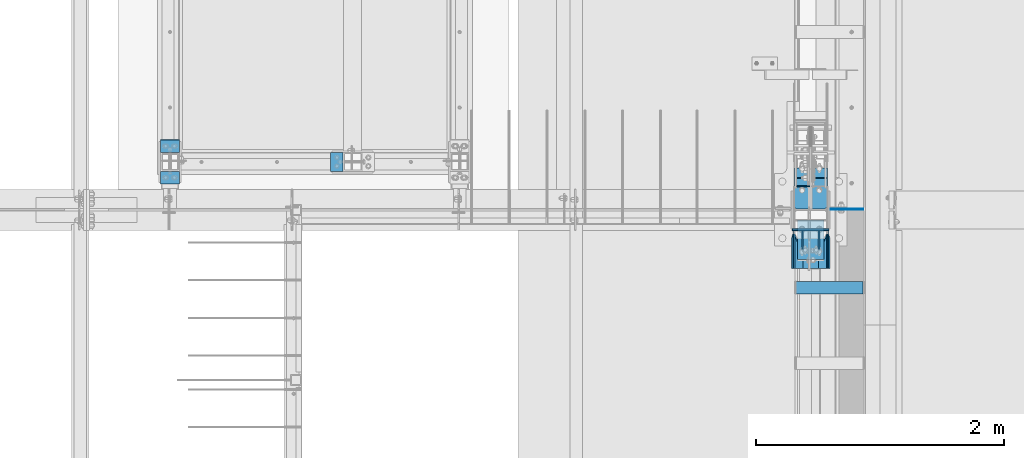
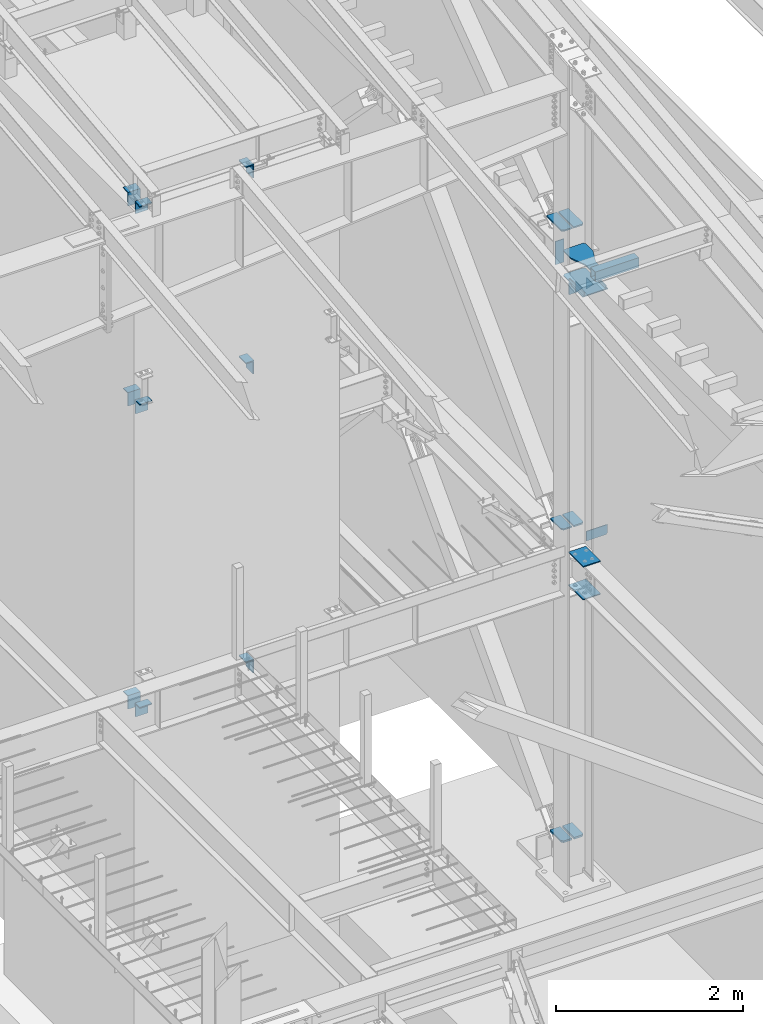
# One storey, part 823 of 1179: 27 beams, 14 elements without a shape of their own.
"""IFC2X3 building model written with IfcOpenShell, lengths in millimetres."""

from ifc_helpers import new_model, si_unit, frame, origin_with_axes, place, context, subcontext, project, spatial, faceted_brep, material, type_object, element, aggregate, save


model = new_model("IFC2X3")

# Units and contexts
model_context = context("Model", 3, precision=1e-05, world=origin_with_axes())
body_context = subcontext(model_context, "Body", "Model", "MODEL_VIEW")
ifc_project = project(units=[si_unit("LENGTHUNIT", "METRE", prefix="MILLI"), si_unit("AREAUNIT", "SQUARE_METRE"), si_unit("VOLUMEUNIT", "CUBIC_METRE"), si_unit("MASSUNIT", "GRAM", prefix="KILO"), si_unit("TIMEUNIT", "SECOND"), si_unit("PLANEANGLEUNIT", "RADIAN"), si_unit("SOLIDANGLEUNIT", "STERADIAN"), si_unit("THERMODYNAMICTEMPERATUREUNIT", "DEGREE_CELSIUS"), si_unit("LUMINOUSINTENSITYUNIT", "LUMEN")], contexts=[model_context])

# Site, building, storey
site_placement = place(None, origin_with_axes())
site = spatial("IfcSite", under=ifc_project, at=site_placement, CompositionType="ELEMENT")
building_placement = place(site_placement, origin_with_axes())
building = spatial("IfcBuilding", under=site, at=building_placement, Name="Undefined", CompositionType="ELEMENT")
storey_placement = place(building_placement, origin_with_axes())
storey = spatial("IfcBuildingStorey", under=building, at=storey_placement, Name="Undefined", CompositionType="ELEMENT", Elevation=0.0)

# Assembly, beams
assembly_1_placement = place(storey_placement, origin_with_axes())
assembly_1 = element("IfcElementAssembly", 1, at=assembly_1_placement, inside=storey, Name="COLUMN", AssemblyPlace="NOTDEFINED", PredefinedType="RIGID_FRAME")
ifc_material_1 = material(Name="STEEL/A36")
beam_type_1 = type_object("IfcBeamType", PredefinedType="NOTDEFINED")
beam_1_placement = place(assembly_1_placement, frame((19138.9, 12045.9499984741, 7658.1), z_axis=(1.0, 0.0, 0.0), x_axis=(0.0, -1.0, 0.0)))
beam_1 = element("IfcBeam", 2, at=beam_1_placement, type_object=beam_type_1, material=ifc_material_1, Name="BENT_PLATE", context=body_context, shape_type="Brep", body=[
    faceted_brep([(7.27595761418343e-12, -6.35000000000036, -76.1999999999971), (0.0, -6.35000000000036, 76.2000000000044), (0.0, 6.35000000000036, 76.2000000000044), (-7.27595761418343e-12, 6.35000000000036, -76.1999999999971), (88.8999984741222, 6.34999999999991, 76.2000000000007), (88.8999984741222, 6.34999999999991, -76.2000000000007), (101.599998474123, -6.34999999999991, -76.2000000000007), (101.599998474123, -6.34999999999991, 76.2000000000007), (88.8999984741222, 171.450003051757, 76.2000000000007), (88.8999984741222, 171.450003051757, -76.2000000000007), (101.599998474123, 171.450003051757, 76.2000000000007), (101.599998474123, 171.450003051757, -76.2000000000007)], [[[0, 1, 2, 3]], [[3, 2, 4, 5]], [[1, 0, 6, 7]], [[5, 4, 8, 9]], [[4, 2, 1, 7, 10, 8]], [[7, 6, 11, 10]], [[6, 0, 3, 5, 9, 11]], [[10, 11, 9, 8]]]),
])
beam_2_placement = place(assembly_1_placement, frame((19138.9, 11690.3500015259, 7658.1), z_axis=(1.0, 0.0, 0.0), x_axis=(0.0, 1.0, 0.0)))
beam_2 = element("IfcBeam", 3, at=beam_2_placement, type_object=beam_type_1, material=ifc_material_1, Name="BENT_PLATE", context=body_context, shape_type="Brep", body=[
    faceted_brep([(7.27595761418343e-12, -6.35000000000036, -76.1999999999971), (0.0, -6.35000000000036, 76.2000000000044), (0.0, 6.35000000000036, 76.2000000000044), (-7.27595761418343e-12, 6.35000000000036, -76.1999999999971), (101.599998474123, 6.34999999999991, 76.2000000000007), (101.599998474123, 6.34999999999991, -76.2000000000007), (88.8999984741222, -6.34999999999991, -76.2000000000007), (88.8999984741222, -6.34999999999991, 76.2000000000007), (101.599998474123, -171.450003051757, 76.2000000000007), (101.599998474123, -171.450003051757, -76.2000000000007), (88.8999984741222, -171.450003051757, 76.2000000000007), (88.8999984741222, -171.450003051757, -76.2000000000007)], [[[0, 1, 2, 3]], [[3, 2, 4, 5]], [[1, 0, 6, 7]], [[5, 4, 8, 9]], [[4, 2, 1, 7, 10, 8]], [[7, 6, 11, 10]], [[6, 0, 3, 5, 9, 11]], [[10, 11, 9, 8]]]),
])
aggregate(assembly_1, [beam_1, beam_2])

assembly_2_placement = place(storey_placement, origin_with_axes())
assembly_2 = element("IfcElementAssembly", 4, at=assembly_2_placement, inside=storey, Name="COLUMN", AssemblyPlace="NOTDEFINED", PredefinedType="RIGID_FRAME")
beam_3_placement = place(assembly_2_placement, frame((19138.899794654, 12045.9499984741, 3692.52499649481), z_axis=(1.0, 0.0, 0.0), x_axis=(0.0, -1.0, 0.0)))
beam_3 = element("IfcBeam", 5, at=beam_3_placement, type_object=beam_type_1, material=ifc_material_1, Name="BENT_PLATE", context=body_context, shape_type="Brep", body=[
    faceted_brep([(7.27595761418343e-12, -6.35000000000036, -76.1999999999971), (0.0, -6.35000000000036, 76.2000000000044), (0.0, 6.35000000000036, 76.2000000000044), (-7.27595761418343e-12, 6.35000000000036, -76.1999999999971), (88.8999984741222, 6.34999999999991, 76.2000000000007), (88.8999984741222, 6.34999999999991, -76.2000000000007), (101.599998474123, -6.34999999999991, -76.2000000000007), (101.599998474123, -6.34999999999991, 76.2000000000007), (88.8999984741222, 171.450003051757, 76.2000000000007), (88.8999984741222, 171.450003051757, -76.2000000000007), (101.599998474123, 171.450003051757, 76.2000000000007), (101.599998474123, 171.450003051757, -76.2000000000007)], [[[0, 1, 2, 3]], [[3, 2, 4, 5]], [[1, 0, 6, 7]], [[5, 4, 8, 9]], [[4, 2, 1, 7, 10, 8]], [[7, 6, 11, 10]], [[6, 0, 3, 5, 9, 11]], [[10, 11, 9, 8]]]),
])
beam_4_placement = place(assembly_2_placement, frame((19138.899794654, 11690.3500015259, 3692.52499649481), z_axis=(1.0, 0.0, 0.0), x_axis=(0.0, 1.0, 0.0)))
beam_4 = element("IfcBeam", 6, at=beam_4_placement, type_object=beam_type_1, material=ifc_material_1, Name="BENT_PLATE", context=body_context, shape_type="Brep", body=[
    faceted_brep([(7.27595761418343e-12, -6.35000000000036, -76.1999999999971), (0.0, -6.35000000000036, 76.2000000000044), (0.0, 6.35000000000036, 76.2000000000044), (-7.27595761418343e-12, 6.35000000000036, -76.1999999999971), (101.599998474123, 6.34999999999991, 76.2000000000007), (101.599998474123, 6.34999999999991, -76.2000000000007), (88.8999984741222, -6.34999999999991, -76.2000000000007), (88.8999984741222, -6.34999999999991, 76.2000000000007), (101.599998474123, -171.450003051757, 76.2000000000007), (101.599998474123, -171.450003051757, -76.2000000000007), (88.8999984741222, -171.450003051757, 76.2000000000007), (88.8999984741222, -171.450003051757, -76.2000000000007)], [[[0, 1, 2, 3]], [[3, 2, 4, 5]], [[1, 0, 6, 7]], [[5, 4, 8, 9]], [[4, 2, 1, 7, 10, 8]], [[7, 6, 11, 10]], [[6, 0, 3, 5, 9, 11]], [[10, 11, 9, 8]]]),
])
aggregate(assembly_2, [beam_3, beam_4])

# Assembly, beam
assembly_3_placement = place(storey_placement, origin_with_axes())
assembly_3 = element("IfcElementAssembly", 7, at=assembly_3_placement, inside=storey, Name="COLUMN", AssemblyPlace="NOTDEFINED", PredefinedType="RIGID_FRAME")
beam_5_placement = place(assembly_3_placement, frame((20434.3000015259, 11868.15, 7658.1), z_axis=(0.0, 1.0, 0.0), x_axis=(1.0, 0.0, 0.0)))
beam_5 = element("IfcBeam", 8, at=beam_5_placement, type_object=beam_type_1, material=ifc_material_1, Name="BENT_PLATE", context=body_context, shape_type="Brep", body=[
    faceted_brep([(7.27595761418343e-12, -6.35000000000036, -76.1999999999971), (0.0, -6.35000000000036, 76.2000000000044), (0.0, 6.35000000000036, 76.2000000000044), (-7.27595761418343e-12, 6.35000000000036, -76.1999999999971), (88.8999984741222, 6.34999999999991, 76.2000000000007), (88.8999984741222, 6.34999999999991, -76.2000000000007), (101.599998474123, -6.34999999999991, -76.2000000000007), (101.599998474123, -6.34999999999991, 76.2000000000007), (88.8999984741222, 171.450003051757, 76.2000000000007), (88.8999984741222, 171.450003051757, -76.2000000000007), (101.599998474123, 171.450003051757, 76.2000000000007), (101.599998474123, 171.450003051757, -76.2000000000007)], [[[0, 1, 2, 3]], [[3, 2, 4, 5]], [[1, 0, 6, 7]], [[5, 4, 8, 9]], [[4, 2, 1, 7, 10, 8]], [[7, 6, 11, 10]], [[6, 0, 3, 5, 9, 11]], [[10, 11, 9, 8]]]),
])
aggregate(assembly_3, [beam_5])

# Assembly, beams
assembly_4_placement = place(storey_placement, origin_with_axes())
assembly_4 = element("IfcElementAssembly", 9, at=assembly_4_placement, inside=storey, Name="COLUMN", AssemblyPlace="NOTDEFINED", PredefinedType="RIGID_FRAME")
beam_6_placement = place(assembly_4_placement, frame((19138.9, 12046.6686266753, 10288.708863098), z_axis=(1.0, 0.0, 0.0), x_axis=(2.37931089941412e-10, -0.993575662698832, -0.113169794965695)))
beam_6 = element("IfcBeam", 10, at=beam_6_placement, type_object=beam_type_1, material=ifc_material_1, Name="BENT_PLATE", context=body_context, shape_type="Brep", body=[
    faceted_brep([(7.27595761418343e-12, -6.35000000000036, -76.1999999999971), (0.0, -6.35000000000036, 76.2000000000044), (0.0, 6.35000000000036, 76.2000000000044), (-7.27595761418343e-12, 6.35000000000036, -76.1999999999971), (90.9468588647287, 6.35000004562426, 76.2000000000007), (90.9468588647287, 6.35000004562426, -76.2000000000007), (102.284159680639, -6.34999994868303, -76.2000000000007), (102.284159680639, -6.34999994868303, 76.2000000000007), (109.787335175104, 171.984030604186, 76.2000000000007), (109.787335175104, 171.984030604186, -76.2000000000007), (122.405964338148, 170.548691604019, 76.2000000000007), (122.405964338148, 170.548691604019, -76.2000000000007)], [[[0, 1, 2, 3]], [[3, 2, 4, 5]], [[1, 0, 6, 7]], [[5, 4, 8, 9]], [[4, 2, 1, 7, 10, 8]], [[7, 6, 11, 10]], [[6, 0, 3, 5, 9, 11]], [[10, 11, 9, 8]]]),
])
beam_7_placement = place(assembly_4_placement, frame((19138.9, 11691.7055089898, 10248.5067435805), z_axis=(1.0, 0.0, 0.0), x_axis=(0.0, 0.993676146336441, 0.112284087038017)))
beam_7 = element("IfcBeam", 11, at=beam_7_placement, type_object=beam_type_1, material=ifc_material_1, Name="BENT_PLATE", context=body_context, shape_type="Brep", body=[
    faceted_brep([(7.27595761418343e-12, -6.35000000000036, -76.1999999999971), (0.0, -6.35000000000036, 76.2000000000044), (0.0, 6.35000000000036, 76.2000000000044), (-7.27595761418343e-12, 6.35000000000036, -76.1999999999971), (101.599998474123, 6.34999999999991, 76.2000000000007), (101.599998474123, 6.34999999999991, -76.2000000000007), (87.3840912620235, -6.35000000880973, -76.2000000000007), (87.3840912620235, -6.35000000880973, 76.2000000000007), (83.5423060723097, -153.454462787842, 76.2000000000007), (83.5423060723097, -153.454462787842, -76.2000000000007), (70.9226190138452, -152.02845488246, 76.2000000000007), (70.9226190138452, -152.02845488246, -76.2000000000007)], [[[0, 1, 2, 3]], [[3, 2, 4, 5]], [[1, 0, 6, 7]], [[5, 4, 8, 9]], [[4, 2, 1, 7, 10, 8]], [[7, 6, 11, 10]], [[6, 0, 3, 5, 9, 11]], [[10, 11, 9, 8]]]),
])
aggregate(assembly_4, [beam_6, beam_7])

# Assembly, beam
assembly_5_placement = place(storey_placement, origin_with_axes())
assembly_5 = element("IfcElementAssembly", 12, at=assembly_5_placement, inside=storey, Name="COLUMN", AssemblyPlace="NOTDEFINED", PredefinedType="RIGID_FRAME")
beam_8_placement = place(assembly_5_placement, frame((20434.3000015259, 11868.15, 10225.285937), z_axis=(0.0, 1.0, 0.0), x_axis=(1.0, 0.0, 0.0)))
beam_8 = element("IfcBeam", 13, at=beam_8_placement, type_object=beam_type_1, material=ifc_material_1, Name="BENT_PLATE", context=body_context, shape_type="Brep", body=[
    faceted_brep([(7.27595761418343e-12, -6.35000000000036, -76.1999999999971), (0.0, -6.35000000000036, 76.2000000000044), (0.0, 6.35000000000036, 76.2000000000044), (-7.27595761418343e-12, 6.35000000000036, -76.1999999999971), (88.8999984741222, 6.34999999999991, 76.2000000000007), (88.8999984741222, 6.34999999999991, -76.2000000000007), (101.599998474123, -6.34999999999991, -76.2000000000007), (101.599998474123, -6.34999999999991, 76.2000000000007), (88.8999984741222, 171.450003051757, 76.2000000000007), (88.8999984741222, 171.450003051757, -76.2000000000007), (101.599998474123, 171.450003051757, 76.2000000000007), (101.599998474123, 171.450003051757, -76.2000000000007)], [[[0, 1, 2, 3]], [[3, 2, 4, 5]], [[1, 0, 6, 7]], [[5, 4, 8, 9]], [[4, 2, 1, 7, 10, 8]], [[7, 6, 11, 10]], [[6, 0, 3, 5, 9, 11]], [[10, 11, 9, 8]]]),
])
aggregate(assembly_5, [beam_8])

assembly_6_placement = place(storey_placement, origin_with_axes())
assembly_6 = element("IfcElementAssembly", 14, at=assembly_6_placement, inside=storey, Name="COLUMN", AssemblyPlace="NOTDEFINED", PredefinedType="RIGID_FRAME")
beam_9_placement = place(assembly_6_placement, frame((24160.1625, 11320.4625, 7620.00000000912), z_axis=(0.0, 0.0, 1.0), x_axis=(1.0, 0.0, 0.0)))
beam_9 = element("IfcBeam", 15, at=beam_9_placement, type_object=beam_type_1, material=ifc_material_1, Name="PLATE", context=body_context, shape_type="Brep", body=[
    faceted_brep([(-7.27595761418343e-12, 6.35000000000036, -76.1999999999971), (0.0, 6.35000000000036, 76.2000000000044), (295.274999999994, 6.34999999999854, 76.2000000000007), (295.274999999994, 6.34999999999854, -76.2000000000007), (0.0, -6.35000000000036, 76.2000000000044), (295.274999999994, -6.34999999999854, 76.2000000000007), (7.27595761418343e-12, -6.35000000000036, -76.1999999999971), (295.274999999994, -6.34999999999854, -76.2000000000007)], [[[0, 1, 2, 3]], [[1, 4, 5, 2]], [[4, 6, 7, 5]], [[6, 0, 3, 7]], [[5, 7, 3, 2]], [[6, 4, 1, 0]]]),
])

assembly_7_placement = place(storey_placement, origin_with_axes())
assembly_7 = element("IfcElementAssembly", 16, at=assembly_7_placement, inside=storey, Name="COLUMN", AssemblyPlace="NOTDEFINED", PredefinedType="RIGID_FRAME")
beam_10_placement = place(assembly_7_placement, frame((20434.3000015259, 11868.15, 3746.50000000731), z_axis=(0.0, 1.0, 0.0), x_axis=(1.0, 0.0, 0.0)))
beam_10 = element("IfcBeam", 17, at=beam_10_placement, type_object=beam_type_1, material=ifc_material_1, Name="BENT_PLATE", context=body_context, shape_type="Brep", body=[
    faceted_brep([(7.27595761418343e-12, -6.35000000000036, -76.1999999999971), (0.0, -6.35000000000036, 76.2000000000044), (0.0, 6.35000000000036, 76.2000000000044), (-7.27595761418343e-12, 6.35000000000036, -76.1999999999971), (88.8999984741222, 6.34999999999991, 76.2000000000007), (88.8999984741222, 6.34999999999991, -76.2000000000007), (101.599998474123, -6.34999999999991, -76.2000000000007), (101.599998474123, -6.34999999999991, 76.2000000000007), (88.8999984741222, 171.450003051757, 76.2000000000007), (88.8999984741222, 171.450003051757, -76.2000000000007), (101.599998474123, 171.450003051757, 76.2000000000007), (101.599998474123, 171.450003051757, -76.2000000000007)], [[[0, 1, 2, 3]], [[3, 2, 4, 5]], [[1, 0, 6, 7]], [[5, 4, 8, 9]], [[4, 2, 1, 7, 10, 8]], [[7, 6, 11, 10]], [[6, 0, 3, 5, 9, 11]], [[10, 11, 9, 8]]]),
])
aggregate(assembly_7, [beam_10])

assembly_8_placement = place(storey_placement, origin_with_axes())
assembly_8 = element("IfcElementAssembly", 18, at=assembly_8_placement, inside=storey, Name="PLATE", AssemblyPlace="NOTDEFINED", PredefinedType="RIGID_FRAME")
ifc_material_2 = material(Name="STEEL/A572-GR.50")
beam_type_2 = type_object("IfcBeamType", PredefinedType="NOTDEFINED")
beam_11_placement = place(assembly_8_placement, frame((24381.619, 11734.5860987404, 4353.48812891869), z_axis=(1.0, 0.0, 0.0), x_axis=(0.0, -1.0, 0.0)))
beam_11 = element("IfcBeam", 19, at=beam_11_placement, type_object=beam_type_2, material=ifc_material_2, Name="PLATE", context=body_context, shape_type="Brep", body=[
    faceted_brep([(225.211098339509, -9.52499999999964, 62.7065000000002), (247.436098339509, -9.52499999999964, 40.4815000000017), (247.436098339509, 9.52499999999964, 40.4815000000017), (225.211098339509, 9.52499999999964, 62.7065000000002), (247.436098339509, 9.52499999999964, -62.7065000000002), (6.18456397205591e-11, 9.52499999999964, -62.7065000000084), (0.0, 9.52499999999964, 62.7065000000002), (0.0, -9.52499999999964, 62.7065000000002), (6.18456397205591e-11, -9.52499999999964, -62.7065000000084), (247.436098339509, -9.52499999999964, -62.7065000000002)], [[[0, 1, 2, 3]], [[4, 5, 6, 3, 2]], [[6, 7, 0, 3]], [[7, 8, 9, 1, 0]], [[8, 5, 4, 9]], [[9, 4, 2, 1]], [[8, 7, 6, 5]]]),
])
aggregate(assembly_8, [beam_11])

assembly_9_placement = place(storey_placement, origin_with_axes())
assembly_9 = element("IfcElementAssembly", 20, at=assembly_9_placement, inside=storey, Name="PLATE", AssemblyPlace="NOTDEFINED", PredefinedType="RIGID_FRAME")
beam_12_placement = place(assembly_9_placement, frame((24233.981, 11734.5860987404, 4353.48812891869), z_axis=(-1.0, 0.0, 0.0), x_axis=(0.0, -1.0, 0.0)))
beam_12 = element("IfcBeam", 21, at=beam_12_placement, type_object=beam_type_2, material=ifc_material_2, Name="PLATE", context=body_context, shape_type="Brep", body=[
    faceted_brep([(225.211098339509, -9.52499999999964, 62.7065000000002), (247.436098339509, -9.52499999999964, 40.4815000000017), (247.436098339509, 9.52499999999964, 40.4815000000017), (225.211098339509, 9.52499999999964, 62.7065000000002), (247.436098339509, 9.52499999999964, -62.7065000000002), (6.18456397205591e-11, 9.52499999999964, -62.7065000000084), (0.0, 9.52499999999964, 62.7065000000002), (0.0, -9.52499999999964, 62.7065000000002), (6.18456397205591e-11, -9.52499999999964, -62.7065000000084), (247.436098339509, -9.52499999999964, -62.7065000000002)], [[[0, 1, 2, 3]], [[4, 5, 6, 3, 2]], [[6, 7, 0, 3]], [[7, 8, 9, 1, 0]], [[8, 5, 4, 9]], [[9, 4, 2, 1]], [[8, 7, 6, 5]]]),
])
aggregate(assembly_9, [beam_12])

# Beam
beam_type_3 = type_object("IfcBeamType", PredefinedType="NOTDEFINED")
beam_13_placement = place(assembly_6_placement, frame((24307.8, 11398.2499999481, 3679.82499999946), z_axis=(-1.0, 0.0, 0.0), x_axis=(0.0, -1.0, 0.0)))
beam_13 = element("IfcBeam", 22, at=beam_13_placement, type_object=beam_type_3, material=ifc_material_2, Name="PLATE", context=body_context, shape_type="Brep", body=[
    faceted_brep([(0.0, 6.35000000000036, -107.949999999997), (0.0, 6.35000000000036, 107.949999999997), (317.5, 6.35000000000036, 107.949999999997), (317.5, 6.35000000000036, -107.949999999997), (0.0, -6.35000000000036, 107.949999999997), (317.5, -6.35000000000036, 107.949999999997), (0.0, -6.35000000000036, -107.949999999997), (317.5, -6.35000000000036, -107.949999999997)], [[[0, 1, 2, 3]], [[1, 4, 5, 2]], [[4, 6, 7, 5]], [[6, 0, 3, 7]], [[5, 7, 3, 2]], [[6, 4, 1, 0]]]),
])

beam_14_placement = place(assembly_6_placement, frame((24307.8, 11398.2499999514, 4108.44999999946), z_axis=(-1.0, 0.0, 0.0), x_axis=(0.0, -1.0, 0.0)))
beam_14 = element("IfcBeam", 23, at=beam_14_placement, type_object=beam_type_3, material=ifc_material_2, Name="PLATE", context=body_context, shape_type="Brep", body=[
    faceted_brep([(0.0, 6.35000000000036, -107.949999999997), (0.0, 6.35000000000036, 107.949999999997), (317.5, 6.35000000000036, 107.949999999997), (317.5, 6.35000000000036, -107.949999999997), (0.0, -6.35000000000036, 107.949999999997), (317.5, -6.35000000000036, 107.949999999997), (0.0, -6.35000000000036, -107.949999999997), (317.5, -6.35000000000036, -107.949999999997)], [[[0, 1, 2, 3]], [[1, 4, 5, 2]], [[4, 6, 7, 5]], [[6, 0, 3, 7]], [[5, 7, 3, 2]], [[6, 4, 1, 0]]]),
])

beam_type_4 = type_object("IfcBeamType", PredefinedType="NOTDEFINED")
beam_15_placement = place(assembly_6_placement, frame((24234.775, 11487.15, 8262.24369604468), z_axis=(-1.0, 0.0, 0.0), x_axis=(0.0, 1.0, 0.0)))
beam_15 = element("IfcBeam", 24, at=beam_15_placement, type_object=beam_type_4, material=ifc_material_2, Name="PLATE", context=body_context, shape_type="Brep", body=[
    faceted_brep([(1.81898940354586e-11, -9.52499999999782, 41.2750000000015), (22.2250000000204, -9.525000000006, 63.5), (22.2249999999913, 9.52499999999327, 63.5), (-7.27595761418343e-12, 9.52500000000146, 41.2750000000015), (332.547630477533, 9.52499999999964, 63.5), (332.547630477533, 9.52499999999964, -63.5), (0.0, 9.52500000000146, -63.5), (332.547630477533, -9.52499999999964, 63.5), (0.0, -9.52500000000146, -63.5), (332.547630477533, -9.52499999999964, -63.5)], [[[0, 1, 2, 3]], [[4, 5, 6, 3, 2]], [[7, 4, 2, 1]], [[8, 9, 7, 1, 0]], [[8, 6, 5, 9]], [[7, 9, 5, 4]], [[6, 8, 0, 3]]]),
])

beam_16_placement = place(assembly_6_placement, frame((24380.825, 11487.15, 8262.24369604468), z_axis=(-1.0, 0.0, 0.0), x_axis=(0.0, 1.0, 0.0)))
beam_16 = element("IfcBeam", 25, at=beam_16_placement, type_object=beam_type_4, material=ifc_material_2, Name="PLATE", context=body_context, shape_type="Brep", body=[
    faceted_brep([(22.2250000000204, -9.525000000006, -63.5), (1.81898940354586e-11, -9.52499999999782, -41.2750000000015), (-7.27595761418343e-12, 9.52500000000146, -41.2750000000015), (22.2249999999913, 9.52499999999327, -63.5), (0.0, 9.52500000000146, 63.5), (332.547630477533, 9.52499999999964, 63.5), (332.547630477533, 9.52499999999964, -63.5), (0.0, -9.52500000000146, 63.5), (332.547630477533, -9.52499999999964, 63.5), (332.547630477533, -9.52499999999964, -63.5)], [[[0, 1, 2, 3]], [[4, 5, 6, 3, 2]], [[4, 7, 8, 5]], [[9, 8, 7, 1, 0]], [[6, 9, 0, 3]], [[8, 9, 6, 5]], [[7, 4, 2, 1]]]),
])

# Assembly, beam
assembly_10_placement = place(storey_placement, origin_with_axes())
assembly_10 = element("IfcElementAssembly", 26, at=assembly_10_placement, inside=storey, Name="BEAM", AssemblyPlace="NOTDEFINED", PredefinedType="RIGID_FRAME")
beam_type_5 = type_object("IfcBeamType", PredefinedType="NOTDEFINED")
beam_17_placement = place(assembly_10_placement, frame((24471.3125015259, 11487.1421987986, 4171.95), z_axis=(0.0, 0.0, 1.0), x_axis=(0.999999999556486, 2.97829999855756e-05, 2.29999993865945e-08)))
beam_17 = element("IfcBeam", 27, at=beam_17_placement, type_object=beam_type_5, material=ifc_material_1, Name="PLATE", context=body_context, shape_type="Brep", body=[
    faceted_brep([(261.937500000007, -3.17500000000001, -44.4500000000007), (242.887500000004, -3.17500000000001, -63.5), (242.887500000004, 3.17500000000001, -63.5), (261.937500000007, 3.17500000000001, -44.4500000000007), (0.0, 3.17499999999927, -63.5), (0.0, 3.17499999999927, 63.5), (261.937500000007, 3.17500000000001, 63.5), (0.0, -3.17499999999927, 63.5), (261.937500000007, -3.17500000000001, 63.5), (0.0, -3.17499999999927, -63.5)], [[[0, 1, 2, 3]], [[4, 5, 6, 3, 2]], [[5, 7, 8, 6]], [[8, 7, 9, 1, 0]], [[9, 4, 2, 1]], [[6, 8, 0, 3]], [[9, 7, 5, 4]]]),
])
aggregate(assembly_10, [beam_17])

# Beam
beam_type_6 = type_object("IfcBeamType", PredefinedType="NOTDEFINED")
beam_18_placement = place(assembly_6_placement, frame((24193.5, 11671.3, 7861.3), z_axis=(0.0, 0.0, 1.0), x_axis=(1.0, 0.0, 0.0)))
beam_18 = element("IfcBeam", 28, at=beam_18_placement, type_object=beam_type_6, material=ifc_material_2, Name="PLATE", context=body_context, shape_type="Brep", body=[
    faceted_brep([(0.0, 4.76250000000073, -152.4), (0.0, 4.76250000000073, 152.4), (104.775000000001, 4.76250000000073, 152.4), (104.775000000001, 4.76250000000073, -152.4), (0.0, -4.76250000000073, 152.4), (104.775000000001, -4.76250000000073, 152.4), (0.0, -4.76250000000073, -152.4), (104.775000000001, -4.76250000000073, -152.4)], [[[0, 1, 2, 3]], [[1, 4, 5, 2]], [[4, 6, 7, 5]], [[6, 0, 3, 7]], [[5, 7, 3, 2]], [[6, 4, 1, 0]]]),
])

# Assembly, beam
assembly_11_placement = place(storey_placement, origin_with_axes())
assembly_11 = element("IfcElementAssembly", 29, at=assembly_11_placement, inside=storey, Name="PLATE", AssemblyPlace="NOTDEFINED", PredefinedType="RIGID_FRAME")
beam_type_7 = type_object("IfcBeamType", PredefinedType="NOTDEFINED")
beam_19_placement = place(assembly_11_placement, frame((24232.3935, 11742.2619185331, 267.318748335633), z_axis=(-1.0, 0.0, 0.0), x_axis=(0.0, -1.0, 0.0)))
beam_19 = element("IfcBeam", 30, at=beam_19_placement, type_object=beam_type_7, material=ifc_material_2, Name="PLATE", context=body_context, shape_type="Brep", body=[
    faceted_brep([(255.111918860846, 12.7, 38.8940000000002), (232.886918860846, 12.7, 61.1189999999988), (232.886918860846, -12.7, 61.1189999999988), (255.111918860846, -12.7, 38.8940000000002), (255.111918860846, 12.7, -61.1189999999988), (0.0, 12.7, -61.1189999999988), (0.0, 12.7, 61.1189999999988), (0.0, -12.7, 61.1189999999988), (0.0, -12.7, -61.1189999999988), (255.111918860846, -12.7, -61.1189999999988)], [[[0, 1, 2, 3]], [[4, 5, 6, 1, 0]], [[6, 7, 2, 1]], [[7, 8, 9, 3, 2]], [[8, 5, 4, 9]], [[9, 4, 0, 3]], [[8, 7, 6, 5]]]),
])
aggregate(assembly_11, [beam_19])

assembly_12_placement = place(storey_placement, origin_with_axes())
assembly_12 = element("IfcElementAssembly", 31, at=assembly_12_placement, inside=storey, Name="PLATE", AssemblyPlace="NOTDEFINED", PredefinedType="RIGID_FRAME")
beam_20_placement = place(assembly_12_placement, frame((24383.2065, 11742.2619185331, 267.318748335633), z_axis=(1.0, 0.0, 0.0), x_axis=(0.0, -1.0, 0.0)))
beam_20 = element("IfcBeam", 32, at=beam_20_placement, type_object=beam_type_7, material=ifc_material_2, Name="PLATE", context=body_context, shape_type="Brep", body=[
    faceted_brep([(255.111918860846, 12.7, 38.8940000000002), (232.886918860846, 12.7, 61.1189999999988), (232.886918860846, -12.7, 61.1189999999988), (255.111918860846, -12.7, 38.8940000000002), (255.111918860846, 12.7, -61.1189999999988), (0.0, 12.7, -61.1189999999988), (0.0, 12.7, 61.1189999999988), (0.0, -12.7, 61.1189999999988), (0.0, -12.7, -61.1189999999988), (255.111918860846, -12.7, -61.1189999999988)], [[[0, 1, 2, 3]], [[4, 5, 6, 1, 0]], [[6, 7, 2, 1]], [[7, 8, 9, 3, 2]], [[8, 5, 4, 9]], [[9, 4, 0, 3]], [[8, 7, 6, 5]]]),
])
aggregate(assembly_12, [beam_20])

# Beam
beam_type_8 = type_object("IfcBeamType", PredefinedType="NOTDEFINED")
beam_21_placement = place(assembly_6_placement, frame((24172.8625, 11009.3125, 7727.95000000912), z_axis=(0.0, 0.0, 1.0), x_axis=(0.0, 1.0, 0.0)))
beam_21 = element("IfcBeam", 33, at=beam_21_placement, type_object=beam_type_8, material=ifc_material_1, Name="PLATE", context=body_context, shape_type="Brep", body=[
    faceted_brep([(0.0, 6.34999999999854, -19.0499999999993), (0.0, 6.35000000000036, 19.0499999999993), (317.5, 6.34999999999854, 19.0499999999993), (317.5, 6.34999999999854, -19.0499999999993), (0.0, -6.35000000000036, 19.0499999999993), (317.5, -6.34999999999854, 19.0499999999993), (0.0, -6.34999999999854, -19.0499999999993), (317.5, -6.34999999999854, -19.0499999999993)], [[[0, 1, 2, 3]], [[1, 4, 5, 2]], [[4, 6, 7, 5]], [[6, 0, 3, 7]], [[5, 7, 3, 2]], [[6, 4, 1, 0]]]),
])

beam_22_placement = place(assembly_6_placement, frame((24442.7375, 11009.3125, 7727.95000000912), z_axis=(0.0, 0.0, 1.0), x_axis=(0.0, 1.0, 0.0)))
beam_22 = element("IfcBeam", 34, at=beam_22_placement, type_object=beam_type_8, material=ifc_material_1, Name="PLATE", context=body_context, shape_type="Brep", body=[
    faceted_brep([(0.0, 6.34999999999854, -19.0499999999993), (0.0, 6.35000000000036, 19.0499999999993), (317.5, 6.34999999999854, 19.0499999999993), (317.5, 6.34999999999854, -19.0499999999993), (0.0, -6.35000000000036, 19.0499999999993), (317.5, -6.34999999999854, 19.0499999999993), (0.0, -6.34999999999854, -19.0499999999993), (317.5, -6.34999999999854, -19.0499999999993)], [[[0, 1, 2, 3]], [[1, 4, 5, 2]], [[4, 6, 7, 5]], [[6, 0, 3, 7]], [[5, 7, 3, 2]], [[6, 4, 1, 0]]]),
])

beam_type_9 = type_object("IfcBeamType", PredefinedType="NOTDEFINED")
beam_23_placement = place(assembly_6_placement, frame((24241.125, 11161.7125, 7620.00000000912), z_axis=(0.0, 0.0, 1.0), x_axis=(0.0, 1.0, 0.0)))
beam_23 = element("IfcBeam", 35, at=beam_23_placement, type_object=beam_type_9, material=ifc_material_1, Name="PLATE", context=body_context, shape_type="Brep", body=[
    faceted_brep([(152.4, -4.76249999999709, 76.2), (152.4, -4.76249999999709, -76.2), (152.4, 4.76249999999709, -76.2), (152.4, 4.76249999999709, 76.2), (0.0, 4.76249999999982, 76.1999999999971), (0.0, -4.76249999999982, 76.1999999999971)], [[[0, 1, 2, 3]], [[3, 2, 4]], [[4, 5, 0, 3]], [[0, 5, 1]], [[4, 2, 1, 5]]]),
])

beam_24_placement = place(assembly_6_placement, frame((24374.475, 11161.7125, 7620.00000000912), z_axis=(0.0, 0.0, 1.0), x_axis=(0.0, 1.0, 0.0)))
beam_24 = element("IfcBeam", 36, at=beam_24_placement, type_object=beam_type_9, material=ifc_material_1, Name="PLATE", context=body_context, shape_type="Brep", body=[
    faceted_brep([(152.4, -4.76249999999709, 76.2), (152.4, -4.76249999999709, -76.2), (152.4, 4.76249999999709, -76.2), (152.4, 4.76249999999709, 76.2), (0.0, 4.76249999999982, 76.1999999999971), (0.0, -4.76249999999982, 76.1999999999971)], [[[0, 1, 2, 3]], [[3, 2, 4]], [[4, 5, 0, 3]], [[0, 5, 1]], [[4, 2, 1, 5]]]),
])

# Assembly, beam
assembly_13_placement = place(storey_placement, origin_with_axes())
assembly_13 = element("IfcElementAssembly", 37, at=assembly_13_placement, inside=storey, Name="PLATE", AssemblyPlace="NOTDEFINED", PredefinedType="RIGID_FRAME")
beam_type_10 = type_object("IfcBeamType", PredefinedType="NOTDEFINED")
beam_25_placement = place(assembly_13_placement, frame((24307.8, 11009.3125, 8023.22500000912), z_axis=(1.0, 0.0, 0.0), x_axis=(0.0, 1.0, 0.0)))
beam_25 = element("IfcBeam", 38, at=beam_25_placement, type_object=beam_type_10, material=ifc_material_1, Name="PLATE", context=body_context, shape_type="Brep", body=[
    faceted_brep([(465.137499999997, -7.9375, -114.300000762945), (442.912499999999, -7.9375, -136.525000762944), (442.912500000006, 7.9375, -136.525000762944), (465.137500000004, 7.9375, -114.300000762945), (465.137500000004, 7.9375, 114.300000762938), (442.912500000006, 7.9375, 136.525000762937), (442.912499999999, -7.9375, 136.525000762937), (465.137499999997, -7.9375, 114.300000762938), (96.7084051981856, -7.9375, 63.4999984741225), (96.7084051981856, 7.9375, 63.4999984741225), (0.0, 7.9375, 63.5), (0.0, -7.9375, 63.5), (99.1209783650102, -7.9375, 63.6148350254298), (99.1209783650102, 7.9375, 63.6148350254298), (101.511736446291, -7.9375, 63.958306298744), (101.511736446291, 7.9375, 63.958306298744), (103.859061613901, -7.9375, 64.5273065415386), (103.859061613901, 7.9375, 64.5273065415386), (106.141728770905, -7.9375, 65.3166907123523), (106.141728770905, 7.9375, 65.3166907123523), (284.162490278406, -7.9375, 136.524999999998), (284.162490278406, 7.9375, 136.525000000001), (0.0, -7.9375, -63.5), (0.0, 7.9375, -63.5), (96.7084055018695, 7.9375, -63.5), (96.7084055018695, -7.9375, -63.5), (99.1209785229439, 7.9375, -63.6148365373992), (99.1209785229439, -7.9375, -63.6148365373992), (101.511736462435, 7.9375, -63.9583077692478), (101.511736462435, -7.9375, -63.9583077692478), (103.859061496114, 7.9375, -64.5273079437611), (103.859061496114, -7.9375, -64.5273079437611), (106.141728530831, 7.9375, -65.3166920207259), (106.141728530831, -7.9375, -65.3166920207259), (284.162502485447, -7.9375, -136.525001525879), (284.162502485447, 7.9375, -136.525000000001)], [[[0, 1, 2, 3]], [[4, 5, 6, 7]], [[8, 9, 10, 11]], [[12, 13, 9, 8]], [[14, 15, 13, 12]], [[16, 17, 15, 14]], [[18, 19, 17, 16]], [[20, 21, 19, 18]], [[22, 23, 24, 25]], [[25, 24, 26, 27]], [[27, 26, 28, 29]], [[29, 28, 30, 31]], [[31, 30, 32, 33]], [[34, 33, 32, 35]], [[34, 35, 2, 1]], [[4, 7, 0, 3]], [[7, 6, 20, 18, 16, 14, 12, 8, 11, 22, 25, 27, 29, 31, 33, 34, 1, 0]], [[22, 11, 10, 23]], [[35, 32, 30, 28, 26, 24, 23, 10, 9, 13, 15, 17, 19, 21, 5, 4, 3, 2]], [[21, 20, 6, 5]]]),
])
aggregate(assembly_13, [beam_25])

assembly_14_placement = place(storey_placement, origin_with_axes())
assembly_14 = element("IfcElementAssembly", 39, at=assembly_14_placement, inside=storey, Name="BEAM", AssemblyPlace="NOTDEFINED", PredefinedType="RIGID_FRAME")
ifc_material_3 = material()
beam_type_11 = type_object("IfcBeamType", Name="HSS5X4X3/8", PredefinedType="NOTDEFINED")
beam_26_placement = place(assembly_14_placement, frame((24180.8, 10853.7570385026, 8077.19999998781), z_axis=(0.0, 0.0, 1.0), x_axis=(1.0, 0.0, 0.0)))
beam_26 = element("IfcBeam", 40, at=beam_26_placement, type_object=beam_type_11, material=ifc_material_3, Name="BEAM", ObjectType="HSS5X4X3/8", context=body_context, shape_type="Brep", body=[
    faceted_brep([(9.52500000000146, 41.2750000000015, -53.9750000000004), (9.52500000000146, -41.2750000000015, -53.9750000000004), (549.274999999994, -41.2750000000015, -53.9750000000004), (549.274999999994, 41.2750000000015, -53.9750000000004), (9.52500000000146, -41.2750000000015, 53.9750000000004), (549.274999999994, -41.2750000000015, 53.9750000000004), (9.52500000000146, 41.2750000000015, 53.9750000000004), (549.274999999994, 41.2750000000015, 53.9750000000004), (9.52500000000146, 50.7999999999993, -63.5), (9.52500000000146, 50.7999999999993, 63.5), (549.274999999994, 50.7999999999993, 63.5), (549.274999999994, 50.7999999999993, -63.5), (9.52500000000146, -50.7999999999993, 63.5), (549.274999999994, -50.7999999999993, 63.5), (9.52500000000146, -50.7999999999993, -63.5), (549.274999999994, -50.7999999999993, -63.5)], [[[0, 1, 2, 3]], [[1, 4, 5, 2]], [[4, 6, 7, 5]], [[6, 0, 3, 7]], [[8, 9, 10, 11]], [[9, 12, 13, 10]], [[12, 14, 15, 13]], [[14, 8, 11, 15]], [[13, 15, 11, 10], [5, 7, 3, 2]], [[14, 12, 9, 8], [6, 4, 1, 0]]]),
])
aggregate(assembly_14, [beam_26])

# Beam
beam_type_12 = type_object("IfcBeamType", PredefinedType="NOTDEFINED")
beam_27_placement = place(assembly_6_placement, frame((24307.8, 11009.3125, 7702.55000000912), z_axis=(1.0, 0.0, 0.0), x_axis=(0.0, 1.0, 0.0)))
beam_27 = element("IfcBeam", 41, at=beam_27_placement, type_object=beam_type_12, material=ifc_material_1, Name="PLATE", context=body_context, shape_type="Brep", body=[
    faceted_brep([(465.137500000001, -6.35000000000036, -114.300000762942), (442.9125, -6.35000000000036, -136.52500076294), (442.9125, 6.35000000000036, -136.52500076294), (465.137500000001, 6.35000000000036, -114.300000762942), (465.137500000001, 6.35000000000036, 114.300000762942), (442.9125, 6.35000000000036, 136.52500076294), (442.9125, -6.35000000000036, 136.52500076294), (465.137500000001, -6.35000000000036, 114.300000762942), (241.300006103516, -6.35000000000036, -155.575000000001), (241.300006103516, 6.35000000000036, -155.575000000001), (304.799990844727, 6.35000000000036, -136.52500076294), (304.799990844727, -6.35000000000036, -136.52500076294), (0.0, -6.35000000000036, -155.575000000001), (0.0, -6.35000000000036, 155.575000000001), (0.0, 6.35000000000036, 155.575000000001), (0.0, 6.35000000000036, -155.575000000001), (241.300006103516, -6.35000000000036, 155.575000000001), (241.300006103516, 6.35000000000036, 155.575000000001), (304.799990844727, -6.35000000000036, 136.52500076294), (304.799990844727, 6.35000000000036, 136.52500076294)], [[[0, 1, 2, 3]], [[4, 5, 6, 7]], [[8, 9, 10, 11]], [[11, 10, 2, 1]], [[12, 13, 14, 15]], [[14, 13, 16, 17]], [[18, 19, 17, 16]], [[19, 18, 6, 5]], [[4, 7, 0, 3]], [[10, 9, 15, 14, 17, 19, 5, 4, 3, 2]], [[12, 15, 9, 8]], [[7, 6, 18, 16, 13, 12, 8, 11, 1, 0]]]),
])

aggregate(assembly_6, [beam_18, beam_15, beam_16, beam_23, beam_24, beam_27, beam_9, beam_21, beam_22, beam_13, beam_14])

save(model, "model.ifc")
